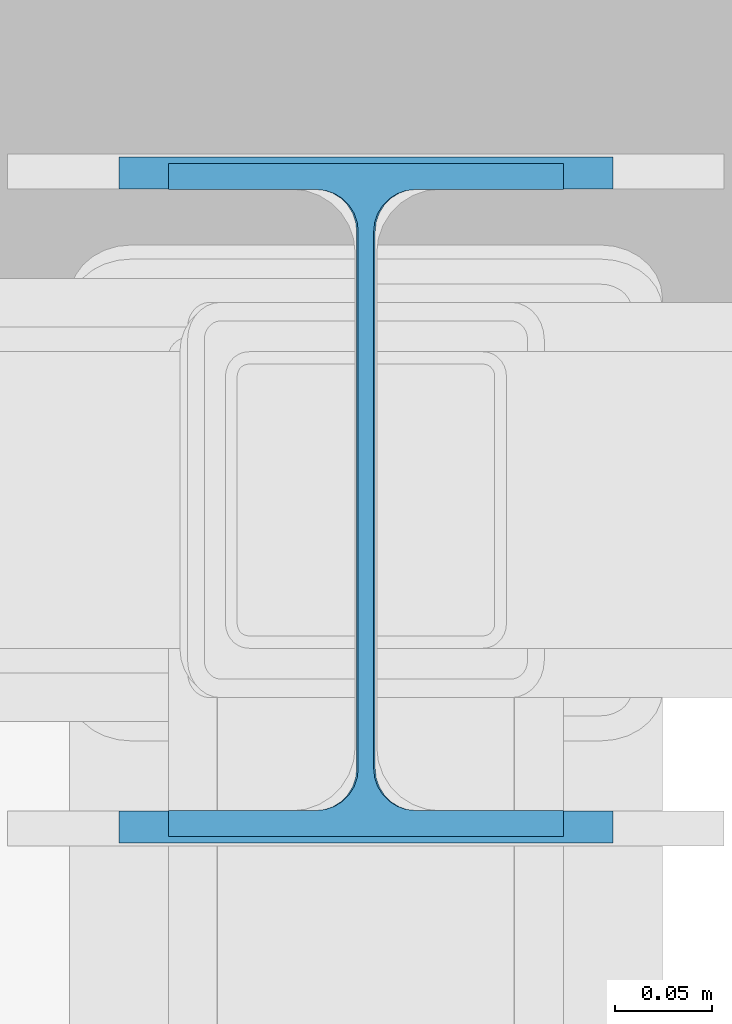
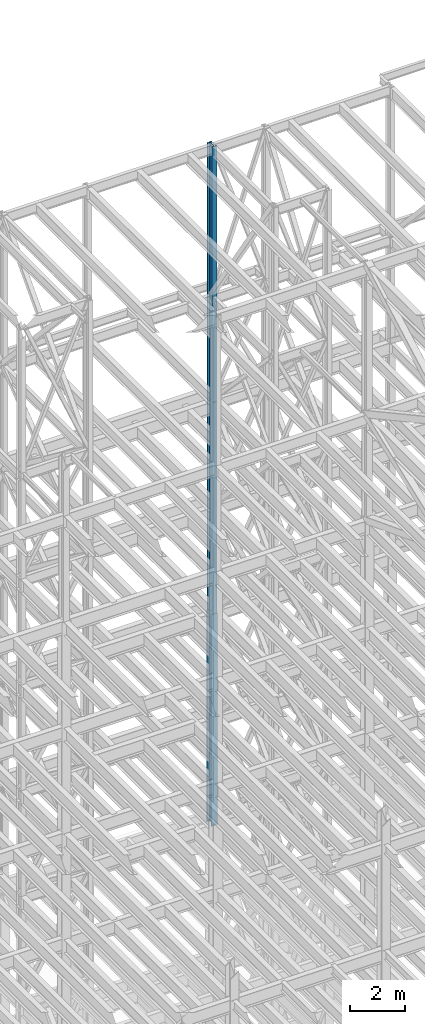
# One storey, part 106 of 150: 3 columns.
"""IFC2X3 building model written with IfcOpenShell, lengths in millimetres."""

from ifc_helpers import new_model, si_unit, frame, origin_with_axes, origin_2d_with_axis, place, context, subcontext, project, spatial, i_section, extrude, material, type_object, element, save


model = new_model("IFC2X3")

# Units and contexts
model_context = context("Model", 3, precision=1e-05, world=origin_with_axes())
body_context = subcontext(model_context, "Body", "Model", "MODEL_VIEW")
ifc_project = project(units=[si_unit("LENGTHUNIT", "METRE", prefix="MILLI"), si_unit("AREAUNIT", "SQUARE_METRE"), si_unit("VOLUMEUNIT", "CUBIC_METRE"), si_unit("MASSUNIT", "GRAM", prefix="KILO"), si_unit("TIMEUNIT", "SECOND"), si_unit("PLANEANGLEUNIT", "RADIAN"), si_unit("SOLIDANGLEUNIT", "STERADIAN"), si_unit("THERMODYNAMICTEMPERATUREUNIT", "DEGREE_CELSIUS"), si_unit("LUMINOUSINTENSITYUNIT", "LUMEN")], contexts=[model_context])

# Site, building, storey
site_placement = place(None, origin_with_axes())
site = spatial("IfcSite", under=ifc_project, at=site_placement, CompositionType="ELEMENT")
building_placement = place(site_placement, origin_with_axes())
building = spatial("IfcBuilding", under=site, at=building_placement, Name="Undefined", CompositionType="ELEMENT")
storey_placement = place(building_placement, origin_with_axes())
storey = spatial("IfcBuildingStorey", under=building, at=storey_placement, Name="Undefined", CompositionType="ELEMENT", Elevation=0.0)

# Columns
ifc_material = material(Name="STEEL/A992")
column_type_1 = type_object("IfcColumnType", Name="W14X43", PredefinedType="NOTDEFINED")
column_1_placement = place(storey_placement, frame((74663.3, 31877.0, 54483.0), z_axis=(0.0, 0.0, 1.0), x_axis=(1.0, 0.0, 0.0)))
element("IfcColumn", 1, at=column_1_placement, inside=storey, type_object=column_type_1, material=ifc_material, Name="COLUMN", ObjectType="W14X43", context=body_context, shape_type="SweptSolid", body=[
    extrude(i_section(OverallWidth=203.2, OverallDepth=346.075, WebThickness=7.9375, FlangeThickness=13.462, FilletRadius=21.4629, at=origin_2d_with_axis()), frame((0.0, 0.0, 11429.998857), z_axis=(0.0, 0.0, -1.0), x_axis=(-1.0, 0.0, 0.0)), (0.0, 0.0, 1.0), 11429.998857),
])
column_2_placement = place(storey_placement, frame((74663.3, 31877.0, 45034.2), z_axis=(0.0, 0.0, 1.0), x_axis=(1.0, 0.0, 0.0)))
element("IfcColumn", 2, at=column_2_placement, inside=storey, type_object=column_type_1, material=ifc_material, Name="COLUMN", ObjectType="W14X43", context=body_context, shape_type="SweptSolid", body=[
    extrude(i_section(OverallWidth=203.2, OverallDepth=346.075, WebThickness=7.9375, FlangeThickness=13.462, FilletRadius=21.4629, at=origin_2d_with_axis()), frame((0.0, 0.0, 9448.8), z_axis=(0.0, 0.0, -1.0), x_axis=(-1.0, 0.0, 0.0)), (0.0, 0.0, 1.0), 9448.8),
])
column_type_2 = type_object("IfcColumnType", Name="W14X61", PredefinedType="NOTDEFINED")
column_3_placement = place(storey_placement, frame((74663.3, 31877.0, 35585.4), z_axis=(0.0, 0.0, 1.0), x_axis=(1.0, 0.0, 0.0)))
element("IfcColumn", 3, at=column_3_placement, inside=storey, type_object=column_type_2, material=ifc_material, Name="COLUMN", ObjectType="W14X61", context=body_context, shape_type="SweptSolid", body=[
    extrude(i_section(OverallWidth=254.0, OverallDepth=352.425, WebThickness=9.5249, FlangeThickness=16.383, FilletRadius=21.717, at=origin_2d_with_axis()), frame((0.0, 0.0, 9448.8), z_axis=(0.0, 0.0, -1.0), x_axis=(-1.0, 0.0, 0.0)), (0.0, 0.0, 1.0), 9448.8),
])

save(model, "model.ifc")
